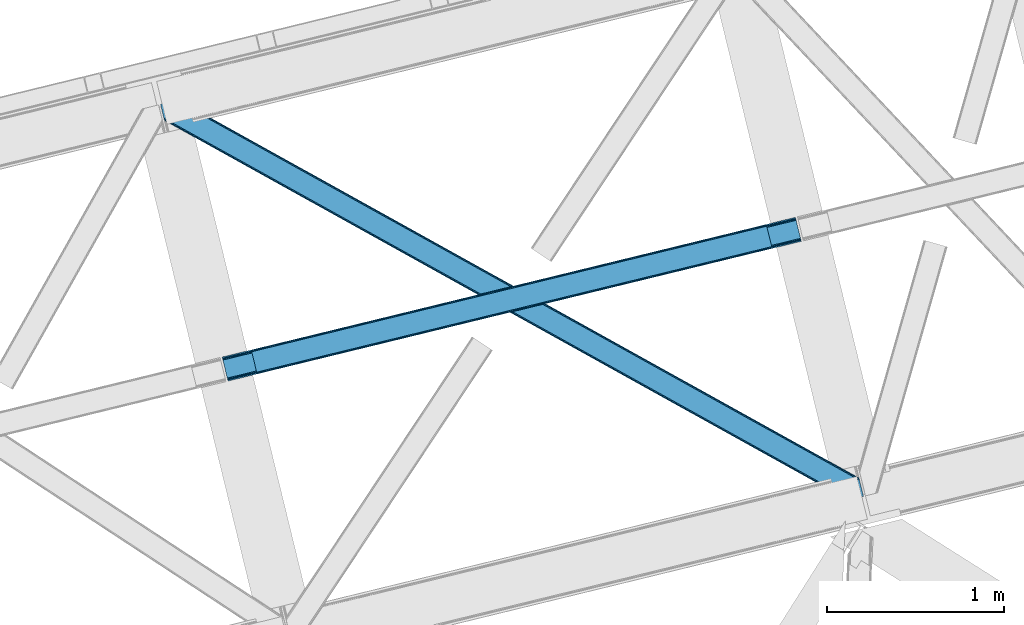
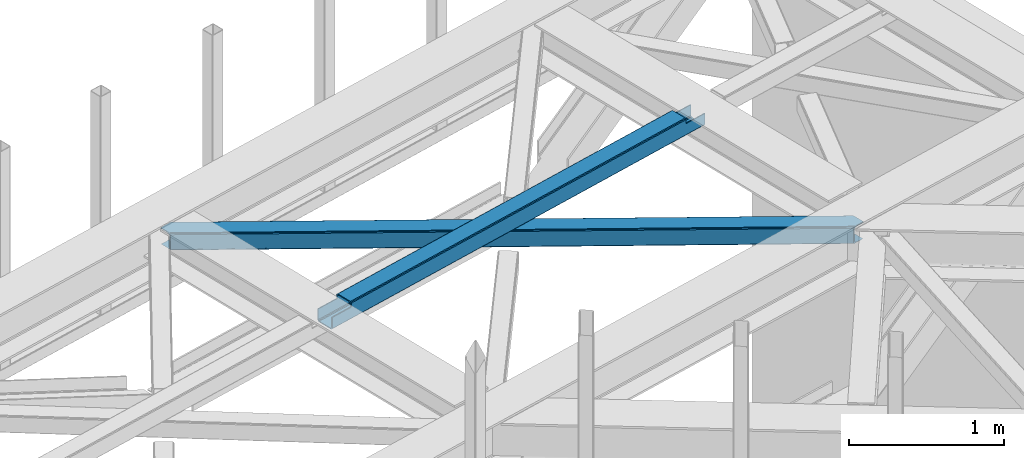
# One storey, part 59 of 66: 1 beam, 1 member.
"""IFC4 building model written with IfcOpenShell, lengths in millimetres."""

from ifc_helpers import new_model, entity, si_unit, converted_unit, derived_unit, direction, frame, origin, place, context, subcontext, project, spatial, triangles, polygons, material, type_object, element, save


model = new_model("IFC4")

# Units and contexts
model_context = context("Model", 3, precision=0.01, world=origin(), true_north=direction((6.12303176911189e-17, 1.0)))
plan_context = context("Plan", 3, precision=0.01, world=origin(), true_north=direction((6.12303176911189e-17, 1.0)))
body_context = subcontext(model_context, "Body", "Model", "MODEL_VIEW")
ifc_project = project(units=[si_unit("LENGTHUNIT", "METRE", prefix="MILLI"), si_unit("AREAUNIT", "SQUARE_METRE"), si_unit("VOLUMEUNIT", "CUBIC_METRE"), converted_unit("PLANEANGLEUNIT", "DEGREE", entity("IfcRatioMeasure", 0.0174532925199433), si_unit("PLANEANGLEUNIT", "RADIAN"), dimensions=[0, 0, 0, 0, 0, 0, 0]), si_unit("MASSUNIT", "GRAM", prefix="KILO"), derived_unit("MASSDENSITYUNIT", [(si_unit("MASSUNIT", "GRAM", prefix="KILO"), 1), (si_unit("LENGTHUNIT", "METRE"), -3)]), derived_unit("MOMENTOFINERTIAUNIT", [(si_unit("LENGTHUNIT", "METRE"), 4)]), si_unit("TIMEUNIT", "SECOND"), si_unit("FREQUENCYUNIT", "HERTZ"), si_unit("THERMODYNAMICTEMPERATUREUNIT", "DEGREE_CELSIUS"), derived_unit("THERMALTRANSMITTANCEUNIT", [(si_unit("MASSUNIT", "GRAM", prefix="KILO"), 1), (si_unit("THERMODYNAMICTEMPERATUREUNIT", "KELVIN"), -1), (si_unit("TIMEUNIT", "SECOND"), -3)]), derived_unit("VOLUMETRICFLOWRATEUNIT", [(si_unit("LENGTHUNIT", "METRE"), 3), (si_unit("TIMEUNIT", "SECOND"), -1)]), derived_unit("MASSFLOWRATEUNIT", [(si_unit("MASSUNIT", "GRAM", prefix="KILO"), 1), (si_unit("TIMEUNIT", "SECOND"), -1)]), derived_unit("ROTATIONALFREQUENCYUNIT", [(si_unit("TIMEUNIT", "SECOND"), -1)]), si_unit("ELECTRICCURRENTUNIT", "AMPERE"), si_unit("ELECTRICVOLTAGEUNIT", "VOLT"), si_unit("POWERUNIT", "WATT"), si_unit("FORCEUNIT", "NEWTON", prefix="KILO"), si_unit("ILLUMINANCEUNIT", "LUX"), si_unit("LUMINOUSFLUXUNIT", "LUMEN"), si_unit("LUMINOUSINTENSITYUNIT", "CANDELA"), derived_unit("USERDEFINED", [(si_unit("MASSUNIT", "GRAM", prefix="KILO"), -1), (si_unit("LENGTHUNIT", "METRE"), -2), (si_unit("TIMEUNIT", "SECOND"), 3), (si_unit("LUMINOUSFLUXUNIT", "LUMEN"), 1)]), derived_unit("LINEARVELOCITYUNIT", [(si_unit("LENGTHUNIT", "METRE"), 1), (si_unit("TIMEUNIT", "SECOND"), -1)]), si_unit("PRESSUREUNIT", "PASCAL"), derived_unit("USERDEFINED", [(si_unit("LENGTHUNIT", "METRE"), -2), (si_unit("MASSUNIT", "GRAM", prefix="KILO"), 1), (si_unit("TIMEUNIT", "SECOND"), -2)]), derived_unit("LINEARFORCEUNIT", [(si_unit("MASSUNIT", "GRAM", prefix="KILO"), 1), (si_unit("LENGTHUNIT", "METRE"), 1), (si_unit("TIMEUNIT", "SECOND"), -2), (si_unit("LENGTHUNIT", "METRE"), -1)]), derived_unit("PLANARFORCEUNIT", [(si_unit("MASSUNIT", "GRAM", prefix="KILO"), 1), (si_unit("LENGTHUNIT", "METRE"), 1), (si_unit("TIMEUNIT", "SECOND"), -2), (si_unit("LENGTHUNIT", "METRE"), -2)])], contexts=[model_context, plan_context])

# Site, building, storey
site_placement = place(None, origin())
site = spatial("IfcSite", under=ifc_project, at=site_placement, CompositionType="ELEMENT")
building_placement = place(site_placement, origin())
building = spatial("IfcBuilding", under=site, at=building_placement, CompositionType="ELEMENT")
storey_placement = place(building_placement, frame((0.0, 0.0, 19800.0)))
storey = spatial("IfcBuildingStorey", under=building, at=storey_placement, Name="06", CompositionType="ELEMENT", Elevation=19800.0)

# Beam
ifc_material = material(Name="Metal painted (White)")
beam_type = type_object("IfcBeamType", PredefinedType="BEAM")
beam_placement = place(storey_placement, frame((-5791.53, 17728.2, 3967.02)))
element("IfcBeam", 1, at=beam_placement, inside=storey, type_object=beam_type, material=ifc_material, ObjectType="Steel Beam", PredefinedType="BEAM", context=body_context, shape_type="Tessellation", body=[
    polygons([(31.1823923917744, 8.09507685196108, 17.8030399336114), (31.4978703677328, 6.80086440699434, 24.4999999999988), (3264.82311986252, 794.958101878828, 24.4999999999988), (3264.50764188657, 796.252314323799, 17.8030399336114), (30.2839871259208, 11.7806820741907, 12.1256313292298), (3263.60923662071, 799.937919546027, 12.1256313292298), (28.9394286278375, 17.2965800886775, 8.33210818105214), (3262.26467812263, 805.453817560513, 8.33210818105214), (27.3534137404024, 23.8030254244704, 7.00000000000274), (3260.6786632352, 811.960262896304, 7.00000000000274), (4.21622439084668, 118.720708051134, 8.33210818105214), (5.80223927828181, 112.214262715345, 7.00000000000274), (3239.12748877308, 900.371500187181, 7.00000000000274), (3237.54147388564, 906.877945522969, 8.33210818105214), (2.87166589276448, 124.236606065622, 12.1256313292342), (3236.19691538756, 912.393843537458, 12.1256313292342), (1.97326062691085, 127.92221128785, 17.8030399336114), (3235.29851012171, 916.079448759688, 17.8030399336114), (1.65778265095034, 129.216423732821, 24.4999999999988), (3234.98303214574, 917.373661204657, 24.4999999999988), (33.1556530186647, 4.33146851719357e-12, 17.5000000000004), (33.1556530186593, 4.33146851719357e-12, 99.499999999999), (31.4978703677263, 6.80086440699434, 99.499999999999), (1.65778265094385, 129.216423732821, 99.499999999999), (1.08286712929839e-11, 136.017288139811, 99.499999999999), (1.73258740687743e-11, 136.017288139811, 17.5000000000004), (0.315477975975662, 134.723075694842, 10.803039933613), (1.2138832418293, 131.037470472615, 5.12563132923143), (2.55844173991258, 125.521572458126, 1.33210818105373), (4.14445662734879, 119.015127122335, 0.0), (29.0111963913332, 17.0021610174804, 0.0), (30.5972112787684, 10.4957156816918, 1.33210818105373), (31.9417697768527, 4.97981766719851, 5.12563132923576), (32.8401750427042, 1.29421244497324, 10.803039933613), (3233.3252494948, 924.174525611642, 17.5000000000004), (3233.3252494948, 924.174525611642, 99.499999999999), (3234.98303214573, 917.373661204653, 99.499999999999), (3264.82311986251, 794.958101878828, 99.499999999999), (3266.48090251344, 788.157237471836, 99.499999999999), (3266.48090251345, 788.157237471836, 17.5000000000004), (3266.16542453748, 789.451449916805, 10.803039933613), (3265.26701927163, 793.137055139028, 5.12563132923576), (3263.92246077355, 798.652953153521, 1.33210818105373), (3262.33644588611, 805.159398489312, 0.0), (3237.46970612213, 907.172364594166, 0.0), (3235.88369123469, 913.678809929959, 1.33210818105373), (3234.53913273661, 919.194707944448, 5.12563132923143), (3233.64072747076, 922.880313166674, 10.803039933613), (3100.63931227489, 754.936562279147, 115.5000123926), (3100.69568035975, 754.950301497761, 100.117303289864), (3101.60237409476, 755.171318256453, 99.499999999999), (194.718606580801, 46.5876811586757, 99.5063429816656), (195.631369831914, 46.8101414945052, 100.117301735448), (195.69016819363, 46.8244741223568, 115.5), (3103.26015674569, 748.370453849465, 99.499999999999), (3102.35359665345, 748.149469675956, 100.117303484932), (3102.29401388578, 748.134946643616, 122.500007895425), (197.345360928053, 40.0229783796045, 122.500002534479), (197.338587096741, 40.02132714415, 100.500009163303), (196.748205195732, 39.8773799905087, 99.5697919021647), (3071.76229593267, 877.586844452971, 99.5063429816656), (3070.85318707321, 877.365274290259, 100.117299778624), (3070.79681898834, 877.351535071645, 115.50000888136), (165.850080476849, 169.240033448186, 115.5), (165.840462203343, 169.237688832044, 100.50000941238), (165.250325295043, 169.093836777333, 99.5761204674868), (3069.73269731775, 884.297145621142, 99.5697919021647), (163.220745767774, 175.804071762186, 99.499999999999), (164.133244938515, 176.026503182399, 100.117301984524), (164.189439987631, 176.040201208968, 122.500002796667), (3069.13568801183, 884.151583079726, 122.500003994045), (3069.14579130066, 884.154046494295, 100.500018741102), (3069.44780216622, 882.856550457563, 129.196959150505), (3070.34113769181, 879.169709115871, 134.874360354937), (3071.68242869587, 873.653014411064, 138.667878733795), (3073.26747578188, 867.146333102988, 139.999985502214), (3098.13822482881, 765.134344553678, 139.999991354279), (3099.7257189464, 758.628259888273, 138.667885332354), (3101.07397850683, 753.113264278044, 134.874367586349), (3101.97774321404, 749.428965811092, 129.196966804773), (3100.3261226432, 756.231332675164, 122.196975799125), (3099.42235793599, 759.915631142118, 127.874376580702), (3098.07409837555, 765.430626752348, 131.667894326702), (3096.48660425796, 771.936711417748, 133.000000348631), (3074.93195508396, 860.347101493819, 132.999995276841), (3073.34690799795, 866.853782801896, 131.667888508414), (3072.00561699389, 872.370477506699, 127.874370129564), (3071.1122814683, 876.057318848393, 122.196968925133), (164.878528418712, 169.003207355194, 99.499999999999), (193.131726453735, 57.3201898040421, 131.667891818946), (191.5457115663, 63.8266351398329, 133.0), (194.476284951819, 51.8042917895531, 127.874368670764), (195.374690217671, 48.1186865673279, 122.196960066391), (169.994537104179, 152.237872430709, 133.0), (166.165558452807, 167.945821003217, 122.196960066391), (167.06396371866, 164.260215780994, 127.874368670764), (168.408522216743, 158.7443177665, 131.667891818946), (197.031411944069, 41.3175635421159, 129.196961104604), (196.136488323061, 45.0040174739024, 134.874366301861), (194.794244157311, 50.5204796458751, 138.667887185257), (193.20902395358, 57.0271186992015, 139.999994588639), (168.341882306938, 159.039986838392, 139.999994981919), (166.755021471188, 165.546225960034, 138.667887628704), (165.408105180731, 171.06154922293, 134.874366787843), (164.506189230964, 174.746298656831, 129.196961619)], [[[1, 2, 3, 4]], [[5, 1, 4, 6]], [[7, 5, 6, 8]], [[9, 7, 8, 10]], [[11, 12, 13, 14]], [[15, 11, 14, 16]], [[17, 15, 16, 18]], [[19, 17, 18, 20]], [[12, 9, 10, 13]], [[21, 22, 23, 2, 1, 5, 7, 9, 12, 11, 15, 17, 19, 24, 25, 26, 27, 28, 29, 30, 31, 32, 33, 34]], [[35, 36, 37, 20, 18, 16, 14, 13, 10, 8, 6, 4, 3, 38, 39, 40, 41, 42, 43, 44, 45, 46, 47, 48]], [[49, 50, 51, 38, 3, 2, 23, 52, 53, 54]], [[55, 39, 38, 51]], [[39, 55, 56, 57, 58, 59, 60, 22, 21, 40]], [[32, 31, 44, 43]], [[33, 32, 43, 42]], [[34, 33, 42, 41]], [[21, 34, 41, 40]], [[31, 30, 45, 44]], [[27, 26, 35, 48]], [[28, 27, 48, 47]], [[29, 28, 47, 46]], [[30, 29, 46, 45]], [[20, 37, 61, 62, 63, 64, 65, 66, 24, 19]], [[67, 36, 35, 26, 25, 68, 69, 70, 71, 72]], [[36, 67, 61, 37]], [[72, 71, 73, 74, 75, 76, 77, 78, 79, 80, 57, 56, 50, 49, 81, 82, 83, 84, 85, 86, 87, 88, 63, 62]], [[60, 52, 23, 22]], [[25, 24, 89, 68]], [[90, 91, 84, 83]], [[92, 90, 83, 82]], [[93, 92, 82, 81]], [[54, 93, 81, 49]], [[94, 85, 84, 91]], [[95, 64, 63, 88]], [[96, 95, 88, 87]], [[97, 96, 87, 86]], [[94, 97, 86, 85]], [[65, 64, 95, 96, 97, 94, 91, 90, 92, 93, 54, 53, 59, 58, 98, 99, 100, 101, 102, 103, 104, 105, 70, 69]], [[98, 58, 57, 80]], [[99, 98, 80, 79]], [[100, 99, 79, 78]], [[101, 100, 78, 77]], [[77, 76, 102, 101]], [[103, 102, 76, 75]], [[104, 103, 75, 74]], [[105, 104, 74, 73]], [[70, 105, 73, 71]]], closed=False),
])

# Member
member_type = type_object("IfcMemberType", PredefinedType="BRACE")
member_placement = place(storey_placement, frame((-6138.83, 17057.18, 3823.02)))
element("IfcMember", 2, at=member_placement, inside=storey, type_object=member_type, ObjectType="Steel Horizontal Brace", PredefinedType="BRACE", context=body_context, shape_type="Tessellation", body=[
    triangles([(3944.44949684143, 102.671640014647, 139.998431396481), (3942.29003562927, 111.53040161133, 138.668280029295), (86.0110290527336, 2252.77993469238, 138.668280029295), (76.4226608276367, 2250.44286804199, 139.998431396481), (3940.45918807983, 119.041571044923, 134.873162841795), (94.1355331420891, 2254.76004638672, 134.873162841795), (3939.23600692749, 124.059869384764, 129.196765136716), (99.5665969848633, 2256.08438415527, 129.196765136716), (3938.80638198853, 125.821389770506, 122.499499511716), (101.473457336426, 2256.5494720459, 122.499499511716), (3314.35932312012, 472.552551269531, 17.4989318847656), (3938.80638198853, 125.821389770506, 17.4989318847656), (2666.27097473145, 832.413143920898, 17.4989318847656), (2018.18262634277, 1192.27257385254, 17.4989318847656), (722.001860046386, 1911.99259643555, 17.4989318847656), (101.473457336426, 2256.5494720459, 17.4989318847656), (1370.0942779541, 1552.13316650391, 17.4989318847656), (3902.06080513, 6.10660400390771, 139.998431396481), (3964.29058227539, 21.2754455566392, 139.998431396481), (16.6437515258785, 2163.53421936035, 139.998431396481), (0.0, 2231.81377258301, 139.998431396481), (3877.00986328125, 0.0, 122.499499511716), (3878.91657829285, 0.465087890625, 129.196765136716), (21.857386779785, 2142.14598999023, 129.196765136716), (22.2870117187495, 2140.38446960449, 122.499499511716), (3884.34793281555, 1.78942565917896, 134.873162841795), (20.6342056274407, 2147.16428833008, 134.873162841795), (3892.47229156494, 3.76953735351708, 138.668280029295), (18.8035034179684, 2154.67545776367, 138.668280029295), (1951.60791091919, 1069.10567321777, 17.4989318847656), (2602.63038253784, 707.617272949217, 17.4989318847656), (3253.65285415649, 346.127709960936, 17.4989318847656), (3877.00986328125, 0.0, 17.4989318847656), (1300.58543930054, 1430.59407348633, 17.4989318847656), (649.563258361816, 1792.08247375488, 17.4989318847656), (22.2870117187495, 2140.38446960449, 17.4989318847656), (19.5999664306637, 2151.40588989258, 122.19719238281), (18.3767852783203, 2156.42418823242, 127.873590087889), (20.0295913696282, 2149.64436950684, 115.49992675781), (20.0295913696282, 2149.64436950684, 24.4985046386719), (19.5999664306637, 2151.40588989258, 17.8035644531228), (18.4942199707029, 2155.94398498535, 12.4992370605469), (22.0515609741205, 2141.34952697754, 12.4992370605469), (16.5460830688471, 2163.93535766601, 131.666381835938), (14.3869125366209, 2172.7941192627, 132.998858642575), (0.0, 2231.81377258301, 132.998858642575), (3887.03192596436, 2.44287414550854, 115.49992675781), (3887.03192596436, 2.44287414550854, 24.4985046386719), (3912.08301315308, 8.54947814941261, 132.998858642575), (3902.49449958801, 6.21241149902198, 131.666381835938), (3894.36563529968, 4.23113708496021, 127.873590087889), (3888.93878631592, 2.90796203613354, 122.19719238281), (3946.70677185059, 93.411740112304, 132.998858642575), (3964.29058227539, 21.2754455566392, 132.998858642575), (66.4005981445307, 2247.99999389648, 132.998858642575), (21.5068267822262, 2161.17971191406, 8.33204956054396), (3894.36563529968, 4.23113708496021, 12.1248413085923), (3888.93878631592, 2.90796203613354, 17.8035644531228), (3902.49449958801, 6.21241149902198, 8.33204956054396), (3912.08301315308, 8.54947814941261, 6.99957275390625), (20.9359313964842, 2169.15945739746, 6.99957275390625), (29.0836898803709, 2142.05646057129, 5.49966430664063), (6.80074768066333, 2233.47181091308, 5.49966430664063), (5.34560394287109, 2233.11718139648, 6.99957275390625), (23.5985595703123, 2141.5053314209, 10.9597961425752), (94.6552688598631, 2254.88678283691, 5.49966430664063), (160.809370422363, 2218.15530395508, 5.49966430664063), (202.882965087891, 2045.55304870605, 5.49966430664063), (3941.06365699768, 116.561489868163, 115.49992675781), (3941.49328193665, 114.798806762694, 122.19719238281), (91.4560455322262, 2254.10659790039, 115.49992675781), (89.5445343017573, 2253.64151000977, 122.19719238281), (3942.71646308899, 109.780508422853, 127.873590087889), (84.1175399780268, 2252.31833496094, 127.873590087889), (3944.54731063843, 102.270501708983, 131.666381835938), (75.9889663696285, 2250.33706054687, 131.666381835938), (91.4560455322262, 2254.10659790039, 24.4985046386719), (84.1175399780268, 2252.31833496094, 12.1248413085923), (89.5445343017573, 2253.64151000977, 17.8035644531228), (99.5665969848633, 2256.08438415527, 10.8016662597656), (66.4005981445307, 2247.99999389648, 6.99957275390625), (75.9889663696285, 2250.33706054687, 8.33204956054396), (3941.06365699768, 116.561489868163, 24.4985046386719), (3939.04168739319, 124.856332397459, 12.4992370605469), (3942.59931907654, 110.261874389649, 12.4992370605469), (3941.49328193665, 114.798806762694, 17.8035644531228), (3940.15760765076, 97.0464019775391, 6.99957275390625), (3958.94512367248, 19.9731994628892, 6.99957275390625), (3939.58642158508, 105.026147460936, 8.33204956054396), (3883.82834243774, 1.66268920898438, 5.49966430664063), (3957.49012527466, 19.6185699462876, 5.49966430664063), (3878.91657829285, 0.465087890625, 10.8016662597656), (3932.0097038269, 124.149398803711, 5.49966430664063), (3937.49512481689, 124.700527954101, 10.9597961425752), (3800.28387794495, 48.0505554199226, 5.49966430664063), (3758.21042861938, 220.652810668944, 5.49966430664063), (162.329626464843, 2216.14147338867, 4.49972534179688), (166.107302856445, 2200.64358215332, 0.0), (199.965701293945, 2061.74275817871, 0.0), (163.947550964355, 2209.50234375, 1.33247680663771), (203.74395904541, 2046.24486694336, 4.49972534179688), (202.125453186035, 2052.88283386231, 1.33247680663771), (3311.87081222534, 468.07142944336, 5.12526855468604), (3313.71430435181, 471.388668823241, 10.8016662597656), (3309.11691055298, 463.107778930666, 1.33247680663771), (3757.3497253418, 219.960992431639, 4.49972534179688), (719.513058471679, 1907.51031188965, 5.12526855468604), (716.759156799316, 1902.54782409668, 1.33247680663771), (721.356550598144, 1910.82755126953, 10.8016662597656), (161.571533203125, 2217.14838867187, 4.99969482421875), (713.509355163574, 1896.69353027344, 0.0), (3758.96794052124, 213.323025512695, 1.33247680663771), (3761.12754707336, 204.463101196288, 0.0), (3305.86710891724, 457.253485107423, 0.0), (1364.84750518799, 1542.68723144531, 1.33247680663771), (1361.59770355225, 1536.83293762207, 0.0), (2012.93585357666, 1182.82780151367, 1.33247680663771), (2009.68605194092, 1176.9723449707, 0.0), (2661.02885284424, 822.968371582032, 1.33247680663771), (2657.77440032959, 817.112915039063, 0.0), (1367.60605773926, 1547.65204467774, 5.12526855468604), (2015.69440612793, 1187.79145202637, 5.12526855468604), (2663.7827545166, 827.932022094727, 5.12526855468604), (1369.44489898682, 1550.96812133789, 10.8016662597656), (2017.53324737549, 1191.10752868652, 10.8016662597656), (2665.62595596313, 831.248098754884, 10.8016662597656), (652.05147857666, 1796.56359558105, 5.12526855468604), (650.207986450195, 1793.24635620117, 10.8016662597656), (203.314334106445, 2045.39491882324, 5.42292480468677), (654.805380249023, 1801.52724609375, 1.33247680663771), (3256.14107437134, 350.609994506834, 5.12526855468604), (3258.8949760437, 355.572482299805, 1.33247680663771), (3797.14569740295, 56.7035156249985, 1.33247680663771), (3798.7639125824, 50.0643859863267, 4.49972534179688), (3254.29758224487, 347.292755126953, 10.8016662597656), (3799.52156982422, 49.0574707031265, 4.99969482421875), (3794.98609085083, 65.5622772216811, 0.0), (3262.14477767944, 361.426776123048, 0.0), (658.055181884765, 1807.38153991699, 0.0), (1301.23045806885, 1431.75795593262, 10.8016662597656), (1952.2529296875, 1070.26955566406, 10.8016662597656), (2603.27511062622, 708.781155395507, 10.8016662597656), (1303.07395019531, 1435.0751953125, 5.12526855468604), (1954.09642181396, 1073.58679504395, 5.12526855468604), (2605.11860275269, 712.098394775392, 5.12526855468604), (1305.82785186768, 1440.03884582519, 1.33247680663771), (1956.85032348633, 1078.54928283691, 1.33247680663771), (2607.87250442505, 717.060882568359, 1.33247680663771), (1309.07765350342, 1445.89313964844, 0.0), (1960.10012512207, 1084.40473937988, 0.0), (2611.12259674072, 722.915176391602, 0.0)], [[1, 2, 3], [3, 4, 1], [2, 5, 6], [6, 3, 2], [5, 7, 8], [8, 6, 5], [7, 9, 10], [10, 8, 7], [11, 9, 12], [9, 11, 13], [9, 14, 10], [14, 9, 13], [15, 16, 10], [17, 10, 14], [10, 17, 15], [18, 1, 4], [18, 19, 1], [4, 20, 18], [21, 20, 4], [22, 23, 24], [24, 25, 22], [23, 26, 27], [27, 24, 23], [26, 28, 29], [29, 27, 26], [28, 18, 20], [20, 29, 28], [30, 22, 25], [22, 31, 32], [30, 31, 22], [32, 33, 22], [34, 25, 35], [25, 34, 30], [36, 35, 25], [37, 27, 38], [39, 40, 25], [24, 37, 25], [37, 24, 27], [37, 39, 25], [40, 36, 25], [41, 42, 43], [43, 36, 41], [40, 41, 36], [44, 29, 20], [21, 45, 20], [46, 45, 21], [44, 38, 29], [29, 38, 27], [45, 44, 20], [47, 48, 39], [40, 39, 48], [49, 50, 45], [44, 45, 50], [50, 51, 44], [38, 44, 51], [51, 52, 38], [37, 38, 52], [52, 47, 37], [39, 37, 47], [53, 49, 45], [49, 53, 54], [45, 55, 53], [46, 55, 45], [56, 42, 57], [42, 41, 58], [48, 58, 41], [41, 40, 48], [58, 57, 42], [57, 59, 56], [59, 60, 61], [61, 56, 59], [62, 61, 63], [61, 62, 56], [64, 63, 61], [42, 56, 62], [65, 43, 42], [65, 42, 62], [62, 66, 67], [66, 62, 63], [67, 68, 62], [69, 70, 71], [72, 71, 70], [70, 73, 72], [74, 72, 73], [73, 75, 74], [76, 74, 75], [75, 53, 76], [55, 76, 53], [74, 76, 3], [6, 74, 3], [72, 6, 8], [72, 10, 71], [6, 72, 74], [10, 72, 8], [76, 4, 3], [21, 55, 46], [21, 4, 55], [76, 55, 4], [10, 77, 71], [66, 78, 79], [79, 77, 16], [16, 77, 10], [79, 80, 66], [80, 79, 16], [63, 81, 66], [81, 82, 66], [82, 78, 66], [63, 64, 81], [83, 69, 77], [71, 77, 69], [73, 5, 70], [75, 53, 1], [53, 19, 1], [53, 54, 19], [2, 75, 1], [73, 2, 5], [73, 75, 2], [9, 83, 69], [7, 70, 5], [69, 70, 9], [70, 7, 9], [12, 83, 9], [84, 85, 86], [86, 83, 12], [12, 84, 86], [60, 87, 61], [60, 88, 87], [81, 61, 87], [64, 61, 81], [85, 86, 79], [89, 85, 78], [87, 89, 82], [82, 81, 87], [78, 82, 89], [79, 78, 85], [86, 83, 77], [77, 79, 86], [28, 18, 50], [19, 49, 18], [49, 19, 54], [49, 50, 18], [51, 28, 50], [51, 26, 28], [26, 52, 23], [52, 26, 51], [22, 52, 47], [52, 22, 23], [60, 90, 59], [58, 57, 90], [57, 59, 90], [60, 91, 90], [91, 60, 88], [48, 58, 33], [92, 33, 58], [22, 48, 33], [48, 22, 47], [58, 90, 92], [85, 93, 94], [89, 93, 85], [94, 84, 85], [88, 91, 87], [87, 93, 89], [93, 87, 91], [95, 93, 90], [95, 96, 93], [93, 91, 90], [97, 98, 99], [98, 97, 100], [99, 101, 97], [101, 99, 102], [11, 84, 94], [11, 12, 84], [96, 103, 104], [94, 93, 96], [96, 104, 94], [105, 103, 106], [107, 108, 100], [100, 97, 107], [109, 107, 110], [15, 109, 16], [80, 16, 109], [109, 67, 80], [66, 80, 67], [97, 110, 107], [108, 111, 98], [98, 100, 108], [112, 113, 114], [114, 105, 112], [106, 112, 105], [94, 104, 11], [115, 116, 111], [111, 108, 115], [117, 118, 116], [116, 115, 117], [119, 120, 118], [118, 117, 119], [105, 114, 120], [120, 119, 105], [121, 115, 107], [108, 107, 115], [122, 117, 121], [115, 121, 117], [123, 119, 122], [117, 122, 119], [103, 105, 123], [119, 123, 105], [124, 121, 107], [107, 109, 124], [125, 122, 121], [121, 124, 125], [126, 123, 125], [122, 125, 123], [104, 103, 126], [123, 126, 103], [17, 124, 15], [109, 15, 124], [14, 125, 17], [124, 17, 125], [13, 126, 125], [125, 14, 13], [11, 104, 126], [126, 13, 11], [35, 43, 65], [35, 36, 43], [127, 128, 129], [65, 62, 68], [68, 128, 65], [130, 127, 101], [131, 132, 133], [133, 134, 131], [135, 131, 136], [90, 92, 95], [135, 95, 92], [134, 136, 131], [137, 133, 132], [132, 138, 137], [139, 130, 102], [102, 99, 139], [101, 102, 130], [65, 128, 35], [92, 33, 135], [32, 135, 33], [140, 34, 128], [35, 128, 34], [141, 30, 140], [34, 140, 30], [142, 31, 30], [30, 141, 142], [135, 32, 31], [31, 142, 135], [143, 140, 128], [128, 127, 143], [144, 141, 140], [140, 143, 144], [145, 142, 141], [141, 144, 145], [131, 135, 142], [142, 145, 131], [146, 143, 127], [127, 130, 146], [147, 144, 143], [143, 146, 147], [148, 145, 144], [144, 147, 148], [132, 131, 145], [145, 148, 132], [149, 146, 130], [130, 139, 149], [150, 147, 149], [146, 149, 147], [151, 148, 150], [147, 150, 148], [138, 132, 151], [148, 151, 132], [113, 137, 138], [114, 138, 151], [138, 114, 113], [120, 150, 118], [151, 120, 114], [120, 151, 150], [111, 116, 149], [150, 116, 118], [116, 150, 149], [139, 111, 149], [99, 111, 139], [98, 111, 99], [113, 106, 137], [113, 112, 106], [134, 137, 106], [134, 133, 137]]),
])

save(model, "model.ifc")
